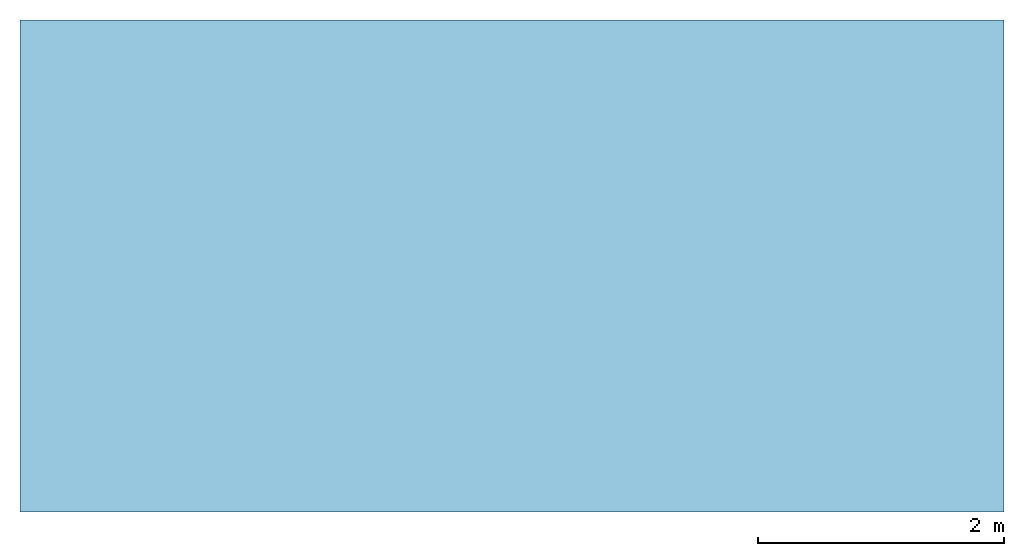
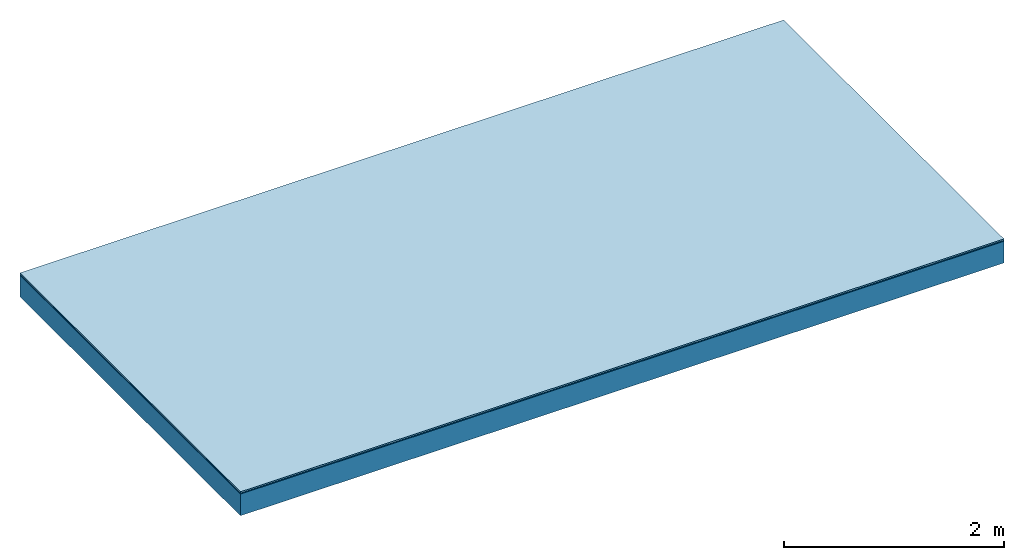
# One storey: 3 plates, 1 member, 1 element without a shape of its own.
"""IFC4 building model written with IfcOpenShell, lengths in metres."""

from ifc_helpers import new_model, si_unit, derived_unit, direction, frame, frame_2d, origin, origin_with_axes, place, context, project, spatial, rectangle, extrude, material, layer, layer_set, type_object, element, aggregate, save


model = new_model("IFC4")

# Units and contexts
plan_context = context("Plan", 3, precision=1e-05, world=origin(), true_north=direction((0.0, 1.0)))
model_context = context("Model", 3, precision=1e-05, world=origin(), true_north=direction((0.0, 1.0)))
ifc_project = project(units=[si_unit("LENGTHUNIT", "METRE"), derived_unit("SOUNDPRESSUREUNIT", [(si_unit("PRESSUREUNIT", "PASCAL", prefix="MICRO"), 0)]), si_unit("ENERGYUNIT", "JOULE", prefix="MEGA"), si_unit("MASSUNIT", "GRAM", prefix="KILO"), derived_unit("THERMALTRANSMITTANCEUNIT", [(si_unit("POWERUNIT", "WATT"), 1), (si_unit("AREAUNIT", "SQUARE_METRE"), -1), (si_unit("THERMODYNAMICTEMPERATUREUNIT", "KELVIN"), -1)]), derived_unit("AREADENSITYUNIT", [(si_unit("MASSUNIT", "GRAM", prefix="KILO"), 1), (si_unit("AREAUNIT", "SQUARE_METRE"), -1)]), derived_unit("USERDEFINED", [(si_unit("ENERGYUNIT", "JOULE", prefix="MEGA"), 1), (si_unit("AREAUNIT", "SQUARE_METRE"), -1)])], contexts=[plan_context, model_context])

# Site, building, storey
site = spatial("IfcSite", under=ifc_project)
building_placement = place(None, origin())
building = spatial("IfcBuilding", under=site, at=building_placement)
storey_placement = place(building_placement, origin())
storey = spatial("IfcBuildingStorey", under=building, at=storey_placement)

# Slab, member, plates
ifc_material_1 = material(Category="11.013")
ifc_layer_1 = layer(ifc_material_1, 0.015, Name="Flooring")
ifc_material_2 = material(Name="Wood fiber generic product", Category="10.009")
ifc_layer_2 = layer(ifc_material_2, 0.01, Name="Impact sound insulation")
ifc_material_3 = material(Name="protection", Category="09.007")
ifc_layer_3 = layer(ifc_material_3, 0.0005, Name="Sub-floor")
ifc_material_4 = material(Name="no composite action")
ifc_layer_4 = layer(ifc_material_4, 0.0, Name="Bond")
ifc_layer_5 = layer(None, 0.24, Name="Supporting structure")
ifc_layer_set = layer_set([ifc_layer_1, ifc_layer_2, ifc_layer_3, ifc_layer_4, ifc_layer_5])
slab_type = type_object("IfcSlabType", Name="A2012", PredefinedType="NOTDEFINED", material=ifc_layer_set)
slab_placement = place(None, frame((0.0, 0.0, 0.0), z_axis=(0.0, 0.0, -1.0), x_axis=(1.0, 0.0, 0.0)))
slab = element("IfcSlab", 1, at=slab_placement, inside=storey, type_object=slab_type, material=ifc_layer_set, Name="Slab #1")
ifc_material_5 = material(Name="Solid timber panel")
member_placement = place(slab_placement, origin())
member = element("IfcMember", 2, at=member_placement, material=ifc_material_5, Name="Supporting structure", context=plan_context, shape_type="SweptSolid", body=[
    extrude(rectangle(XDim=1.0, YDim=0.24, at=frame_2d((0.5, 0.12), x_axis=(1.0, 0.0))), frame((0.0, 4.0, 0.0255), z_axis=(0.0, -1.0, 0.0), x_axis=(1.0, 0.0, 0.0)), (0.0, 0.0, 1.0), 4.0),
    extrude(rectangle(XDim=1.0, YDim=0.24, at=frame_2d((0.5, 0.12), x_axis=(1.0, 0.0))), frame((1.0, 4.0, 0.0255), z_axis=(0.0, -1.0, 0.0), x_axis=(1.0, 0.0, 0.0)), (0.0, 0.0, 1.0), 4.0),
    extrude(rectangle(XDim=1.0, YDim=0.24, at=frame_2d((0.5, 0.12), x_axis=(1.0, 0.0))), frame((2.0, 4.0, 0.0255), z_axis=(0.0, -1.0, 0.0), x_axis=(1.0, 0.0, 0.0)), (0.0, 0.0, 1.0), 4.0),
    extrude(rectangle(XDim=1.0, YDim=0.24, at=frame_2d((0.5, 0.12), x_axis=(1.0, 0.0))), frame((3.0, 4.0, 0.0255), z_axis=(0.0, -1.0, 0.0), x_axis=(1.0, 0.0, 0.0)), (0.0, 0.0, 1.0), 4.0),
    extrude(rectangle(XDim=1.0, YDim=0.24, at=frame_2d((0.5, 0.12), x_axis=(1.0, 0.0))), frame((4.0, 4.0, 0.0255), z_axis=(0.0, -1.0, 0.0), x_axis=(1.0, 0.0, 0.0)), (0.0, 0.0, 1.0), 4.0),
    extrude(rectangle(XDim=1.0, YDim=0.24, at=frame_2d((0.5, 0.12), x_axis=(1.0, 0.0))), frame((5.0, 4.0, 0.0255), z_axis=(0.0, -1.0, 0.0), x_axis=(1.0, 0.0, 0.0)), (0.0, 0.0, 1.0), 4.0),
    extrude(rectangle(XDim=1.0, YDim=0.24, at=frame_2d((0.5, 0.12), x_axis=(1.0, 0.0))), frame((6.0, 4.0, 0.0255), z_axis=(0.0, -1.0, 0.0), x_axis=(1.0, 0.0, 0.0)), (0.0, 0.0, 1.0), 4.0),
    extrude(rectangle(XDim=1.0, YDim=0.24, at=frame_2d((0.5, 0.12), x_axis=(1.0, 0.0))), frame((7.0, 4.0, 0.0255), z_axis=(0.0, -1.0, 0.0), x_axis=(1.0, 0.0, 0.0)), (0.0, 0.0, 1.0), 4.0),
])
plate_1_placement = place(slab_placement, origin())
plate_1 = element("IfcPlate", 3, at=plate_1_placement, material=ifc_material_1, Name="Flooring", context=plan_context, shape_type="SweptSolid", body=[
    extrude(rectangle(XDim=8.0, YDim=4.0, at=frame_2d((4.0, 2.0), x_axis=(1.0, 0.0))), origin_with_axes(), (0.0, 0.0, 1.0), 0.015),
])
plate_2_placement = place(slab_placement, origin())
plate_2 = element("IfcPlate", 4, at=plate_2_placement, material=ifc_material_2, Name="Impact sound insulation", context=plan_context, shape_type="SweptSolid", body=[
    extrude(rectangle(XDim=8.0, YDim=4.0, at=frame_2d((4.0, 2.0), x_axis=(1.0, 0.0))), frame((0.0, 0.0, 0.015), z_axis=(0.0, 0.0, 1.0), x_axis=(1.0, 0.0, 0.0)), (0.0, 0.0, 1.0), 0.01),
])
plate_3_placement = place(slab_placement, origin())
plate_3 = element("IfcPlate", 5, at=plate_3_placement, material=ifc_material_3, Name="Sub-floor", context=plan_context, shape_type="SweptSolid", body=[
    extrude(rectangle(XDim=8.0, YDim=4.0, at=frame_2d((4.0, 2.0), x_axis=(1.0, 0.0))), frame((0.0, 0.0, 0.025), z_axis=(0.0, 0.0, 1.0), x_axis=(1.0, 0.0, 0.0)), (0.0, 0.0, 1.0), 0.0005),
])
aggregate(slab, [plate_1, plate_2, plate_3, member])

save(model, "model.ifc")
